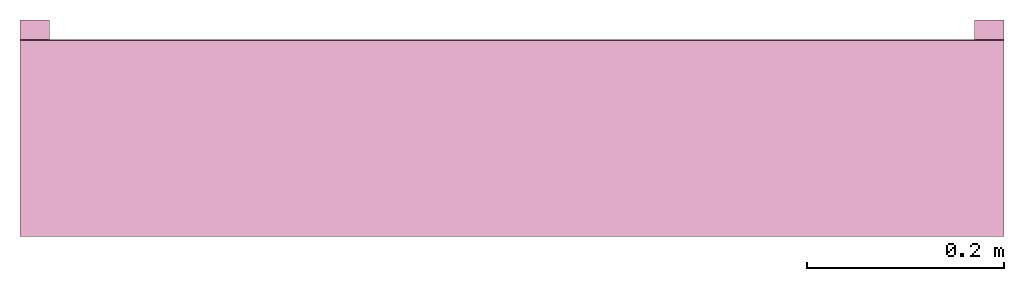
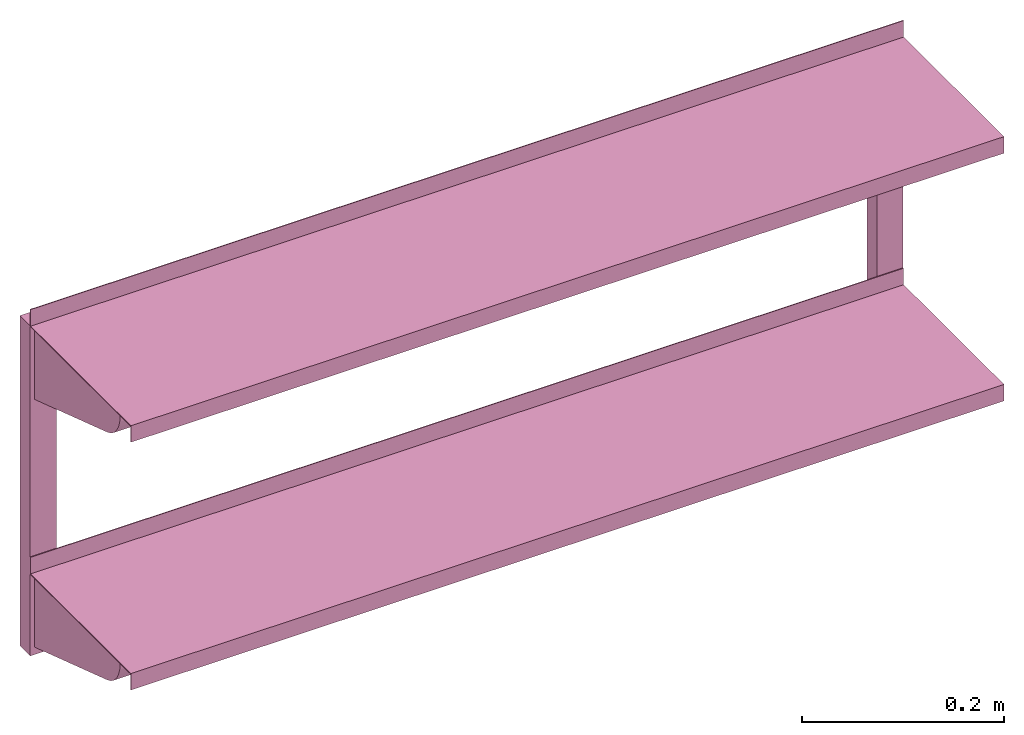
# One storey: 1 furnishing.
"""IFC2X3 building model written with IfcOpenShell, lengths in millimetres."""

from ifc_helpers import new_model, entity, si_unit, converted_unit, derived_unit, direction, frame, frame_2d, origin, place, context, subcontext, project, spatial, polyline, circle_curve, parameter, trimmed, segment, composite_curve, rectangle, outline, extrude, source, transform, mapped, material, type_object, type_shapes, element, save


model = new_model("IFC2X3")

# Units and contexts
model_context = context("Model", 3, precision=0.01, world=origin(), true_north=direction((6.12303176911189e-17, 1.0)))
body_context = subcontext(model_context, "Body", "Model", "MODEL_VIEW")
ifc_project = project(units=[si_unit("LENGTHUNIT", "METRE", prefix="MILLI"), si_unit("AREAUNIT", "SQUARE_METRE"), si_unit("VOLUMEUNIT", "CUBIC_METRE"), converted_unit("PLANEANGLEUNIT", "DEGREE", entity("IfcRatioMeasure", 0.0174532925199433), si_unit("PLANEANGLEUNIT", "RADIAN"), dimensions=[0, 0, 0, 0, 0, 0, 0]), si_unit("MASSUNIT", "GRAM", prefix="KILO"), derived_unit("MASSDENSITYUNIT", [(si_unit("MASSUNIT", "GRAM", prefix="KILO"), 1), (si_unit("LENGTHUNIT", "METRE"), -3)]), si_unit("TIMEUNIT", "SECOND"), si_unit("FREQUENCYUNIT", "HERTZ"), si_unit("THERMODYNAMICTEMPERATUREUNIT", "DEGREE_CELSIUS"), derived_unit("THERMALTRANSMITTANCEUNIT", [(si_unit("MASSUNIT", "GRAM", prefix="KILO"), 1), (si_unit("THERMODYNAMICTEMPERATUREUNIT", "KELVIN"), -1), (si_unit("TIMEUNIT", "SECOND"), -3)]), derived_unit("VOLUMETRICFLOWRATEUNIT", [(si_unit("LENGTHUNIT", "METRE"), 3), (si_unit("TIMEUNIT", "SECOND"), -1)]), si_unit("ELECTRICCURRENTUNIT", "AMPERE"), si_unit("ELECTRICVOLTAGEUNIT", "VOLT"), si_unit("POWERUNIT", "WATT"), si_unit("FORCEUNIT", "NEWTON", prefix="KILO"), si_unit("ILLUMINANCEUNIT", "LUX"), si_unit("LUMINOUSFLUXUNIT", "LUMEN"), si_unit("LUMINOUSINTENSITYUNIT", "CANDELA"), derived_unit("USERDEFINED", [(si_unit("MASSUNIT", "GRAM", prefix="KILO"), -1), (si_unit("LENGTHUNIT", "METRE"), -2), (si_unit("TIMEUNIT", "SECOND"), 3), (si_unit("LUMINOUSFLUXUNIT", "LUMEN"), 1)]), derived_unit("LINEARVELOCITYUNIT", [(si_unit("LENGTHUNIT", "METRE"), 1), (si_unit("TIMEUNIT", "SECOND"), -1)]), si_unit("PRESSUREUNIT", "PASCAL"), derived_unit("USERDEFINED", [(si_unit("LENGTHUNIT", "METRE"), -2), (si_unit("MASSUNIT", "GRAM", prefix="KILO"), 1), (si_unit("TIMEUNIT", "SECOND"), -2)])], contexts=[model_context])

# Site, building, storey
site_placement = place(None, origin())
site = spatial("IfcSite", under=ifc_project, at=site_placement, CompositionType="ELEMENT")
building_placement = place(site_placement, origin())
building = spatial("IfcBuilding", under=site, at=building_placement, CompositionType="ELEMENT")
storey_placement = place(building_placement, origin())
storey = spatial("IfcBuildingStorey", under=building, at=storey_placement, Name="Level 1", CompositionType="ELEMENT", Elevation=0.0)

# Furnishing
ifc_material = material(Name="NBS_Concept")
furniture_type = type_object("IfcFurnitureType", Name="Shelf Units", material=ifc_material)
shared_shape = source(origin(), body_context, "Body", "SweptSolid", [
    extrude(outline(composite_curve([segment(polyline([(-40.791316096028, -28.5663021940636), (111.553687103947, -28.5663021940636)]), True, "CONTINUOUS"), segment(polyline([(111.553687103947, -28.5663021940636), (83.2711916240933, 56.8743230929283)]), True, "CONTINUOUS"), segment(polyline([(83.2711916240934, 56.8743230929283), (-78.116656140222, 3.45183163098292)]), True, "CONTINUOUS"), segment(polyline([(-78.116656140222, 3.45183163098292), (-75.9169064917889, -3.19355033578334)]), True, "CONTINUOUS"), segment(trimmed(circle_curve(frame_2d((-40.7913160960281, 8.43369780593355), x_axis=(-0.314249949776155, 0.949340280966567)), 36.9999999999992), [parameter(90.0000000000003)], [parameter(161.684460106957)], True, "PARAMETER"), True, "CONTINUOUS")], self_intersect=False)), frame((475.0, 371.174881920827, 116.925449628341), z_axis=(1.0, 0.0, 0.0), x_axis=(0.0, -0.31424994977615, -0.949340280966571)), (0.0, 0.0, 1.0), 20.0),
    extrude(outline(composite_curve([segment(polyline([(-40.791316096028, -28.5663021940636), (111.553687103947, -28.5663021940636)]), True, "CONTINUOUS"), segment(polyline([(111.553687103947, -28.5663021940636), (83.2711916240933, 56.8743230929284)]), True, "CONTINUOUS"), segment(polyline([(83.2711916240934, 56.8743230929283), (-78.116656140222, 3.45183163098292)]), True, "CONTINUOUS"), segment(polyline([(-78.116656140222, 3.45183163098292), (-75.9169064917889, -3.19355033578334)]), True, "CONTINUOUS"), segment(trimmed(circle_curve(frame_2d((-40.7913160960281, 8.43369780593355), x_axis=(-0.314249949776183, 0.949340280966567)), 36.9999999999992), [parameter(90.0000000000003)], [parameter(161.684460106957)], True, "PARAMETER"), True, "CONTINUOUS")], self_intersect=False)), frame((-495.0, 371.174881920828, 116.925449628341), z_axis=(1.0, 0.0, 0.0), x_axis=(0.0, -0.31424994977615, -0.949340280966571)), (0.0, 0.0, 1.0), 20.0),
    extrude(outline(polyline([(-99.0, -0.250000000000011), (100.0, -0.250000000000011), (100.0, 19.75), (99.0, 19.75), (99.0, 0.749999999999965), (-100.0, 0.750000000000033), (-100.0, -20.25), (-99.0, -20.2500000000001), (-99.0, -0.250000000000011)])), frame((-500.0, 399.74999999998, 120.0), z_axis=(1.0, 0.0, 0.0), x_axis=(0.0, 0.0, 1.0)), (0.0, 0.0, 1.0), 1000.0),
    extrude(outline(composite_curve([segment(polyline([(-40.791316096028, -28.5663021940637), (111.553687103947, -28.5663021940636)]), True, "CONTINUOUS"), segment(polyline([(111.553687103947, -28.5663021940636), (83.2711916240934, 56.8743230929283)]), True, "CONTINUOUS"), segment(polyline([(83.2711916240934, 56.8743230929283), (-78.116656140222, 3.45183163098289)]), True, "CONTINUOUS"), segment(polyline([(-78.116656140222, 3.45183163098289), (-75.9169064917889, -3.19355033578336)]), True, "CONTINUOUS"), segment(trimmed(circle_curve(frame_2d((-40.7913160960281, 8.43369780593356), x_axis=(-0.314249949776126, 0.949340280966567)), 36.9999999999992), [parameter(90.0000000000003)], [parameter(161.684460106957)], True, "PARAMETER"), True, "CONTINUOUS")], self_intersect=False)), frame((475.0, 71.1748819208266, 116.925449628341), z_axis=(1.0, 0.0, 0.0), x_axis=(0.0, -0.31424994977615, -0.949340280966571)), (0.0, 0.0, 1.0), 20.0),
    extrude(outline(composite_curve([segment(polyline([(-40.791316096028, -28.5663021940636), (111.553687103947, -28.5663021940636)]), True, "CONTINUOUS"), segment(polyline([(111.553687103947, -28.5663021940636), (83.2711916240934, 56.8743230929283)]), True, "CONTINUOUS"), segment(polyline([(83.2711916240934, 56.8743230929283), (-78.116656140222, 3.45183163098289)]), True, "CONTINUOUS"), segment(polyline([(-78.116656140222, 3.45183163098289), (-75.9169064917889, -3.19355033578336)]), True, "CONTINUOUS"), segment(trimmed(circle_curve(frame_2d((-40.7913160960281, 8.43369780593356), x_axis=(-0.314249949776155, 0.949340280966581)), 36.9999999999992), [parameter(90.0000000000003)], [parameter(161.684460106957)], True, "PARAMETER"), True, "CONTINUOUS")], self_intersect=False)), frame((-495.0, 71.1748819208284, 116.925449628341), z_axis=(1.0, 0.0, 0.0), x_axis=(0.0, -0.31424994977615, -0.949340280966571)), (0.0, 0.0, 1.0), 20.0),
    extrude(outline(polyline([(-99.0, -0.250000000000011), (100.0, -0.250000000000011), (100.0, 19.75), (99.0, 19.75), (99.0, 0.749999999999982), (-100.0, 0.750000000000033), (-100.0, -20.25), (-99.0, -20.2500000000001), (-99.0, -0.250000000000011)])), frame((-500.0, 99.7499999999797, 120.0), z_axis=(1.0, 0.0, 0.0), x_axis=(0.0, 0.0, 1.0)), (0.0, 0.0, 1.0), 1000.0),
    extrude(rectangle(XDim=400.0, YDim=29.9999999999999, at=frame_2d((-7.105427357601e-14, 0.0), x_axis=(1.0, 0.0))), frame((485.0, 200.0, 0.0), z_axis=(0.0, 0.0, 1.0), x_axis=(0.0, -1.0, 0.0)), (0.0, 0.0, 1.0), 20.0),
    extrude(rectangle(XDim=400.0, YDim=29.9999999999999, at=frame_2d((-7.105427357601e-14, 6.83897383169096e-14), x_axis=(1.0, 0.0))), frame((-485.0, 200.0, 0.0), z_axis=(0.0, 0.0, 1.0), x_axis=(0.0, -1.0, 0.0)), (0.0, 0.0, 1.0), 20.0),
])
type_shapes(furniture_type, [shared_shape])
furnishing_placement = place(storey_placement, frame((0.0, 0.0, 0.0), z_axis=(0.0, -1.0, 0.0), x_axis=(1.0, 0.0, 0.0)))
element("IfcFurnishingElement", 1, at=furnishing_placement, inside=storey, type_object=furniture_type, material=ifc_material, ObjectType="Shelf Units", context=body_context, shape_type="MappedRepresentation", body=[
    mapped(shared_shape, transform((0.0, 0.0, 0.0), scale=1.0)),
])

save(model, "model.ifc")
